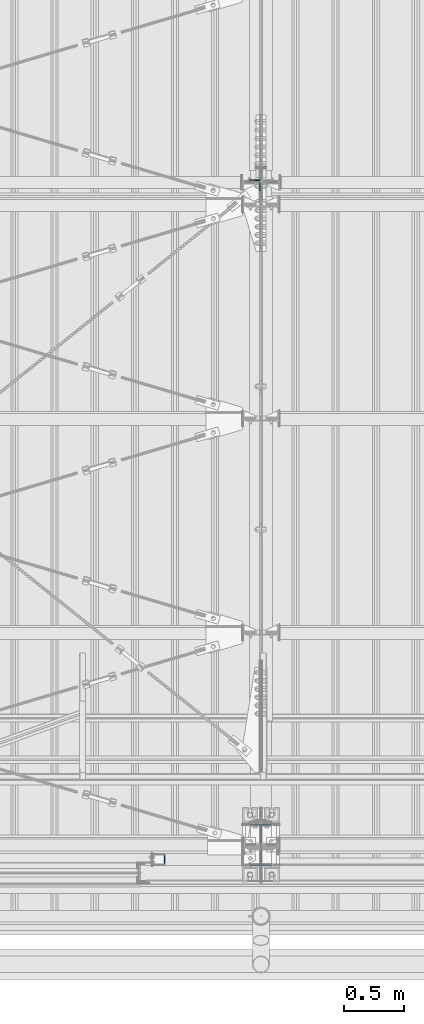
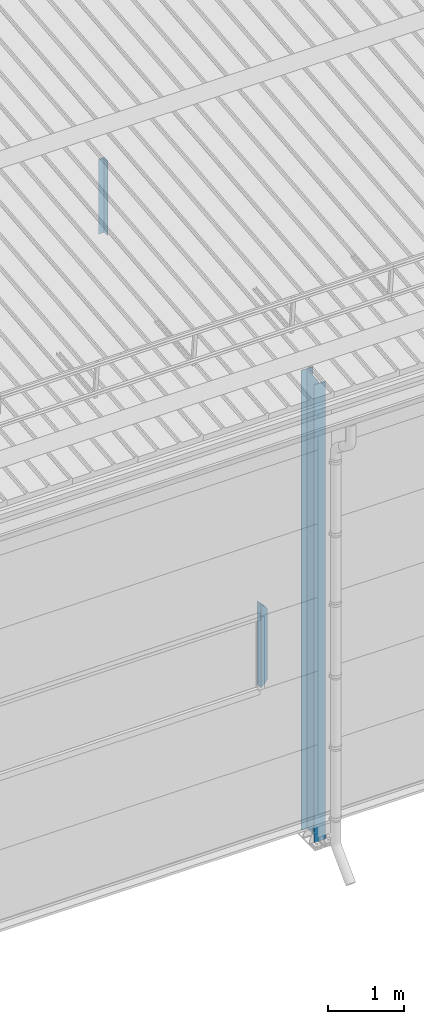
# One storey, part 226 of 709: 3 columns, 3 elements without a shape of their own.
"""IFC4 building model written with IfcOpenShell, lengths in millimetres."""

import ifcopenshell
import ifcopenshell.guid

model = None  # the IFC model being written
_history = None  # IfcOwnerHistory: only IFC2X3 demands one
_inside = {}  # id of a spatial element -> (the spatial element, [elements in it])
_under = {}  # id of a project, library or spatial element -> (it, [spatial elements below it])
_declared = {}  # id of a project -> (the project, [libraries it declares])
_typed = {}  # id of a type object -> (the type object, [elements of that type])
_made_of = {}  # id of a material, layer set ... -> (it, [elements and type objects made of it])


def new_model(schema):
    """Start an empty IFC model of exactly this schema.

    Asked for "IFC4X3", IfcOpenShell would pick the latest addendum, in which some entities
    have other attributes; the version numbers below select the first issue.
    IFC2X3 requires an IfcOwnerHistory on every rooted entity: one is made here for all.
    """
    global model, _history
    if schema == "IFC4X3":
        model = ifcopenshell.file(schema_version=(4, 3, 0, 0))
    else:
        model = ifcopenshell.file(schema=schema)
    _inside.clear()
    _under.clear()
    _declared.clear()
    _typed.clear()
    _made_of.clear()
    _history = None
    if model.schema == "IFC2X3":
        org = make("IfcOrganization", Name="unknown")
        user = make(
            "IfcPersonAndOrganization",
            ThePerson=make("IfcPerson", FamilyName="unknown"),
            TheOrganization=org,
        )
        app = make(
            "IfcApplication",
            ApplicationDeveloper=org,
            Version="unknown",
            ApplicationFullName="unknown",
            ApplicationIdentifier="unknown",
        )
        _history = make(
            "IfcOwnerHistory",
            OwningUser=user,
            OwningApplication=app,
            ChangeAction="ADDED",
            CreationDate=0,
        )
    return model


def make(cls, **values):
    """One entity of the class cls with the attributes given. An attribute that is None is left unset."""
    return model.create_entity(
        cls, **{name: value for name, value in values.items() if value is not None}
    )


def rooted(cls, **values):
    """An entity with a GlobalId (a new one), such as an element, a storey or a relation."""
    return make(cls, GlobalId=ifcopenshell.guid.new(), OwnerHistory=_history, **values)


def si_unit(unit_type, name, prefix=None):
    """IfcSIUnit, for example si_unit("LENGTHUNIT", "METRE", prefix="MILLI")."""
    return make("IfcSIUnit", UnitType=unit_type, Prefix=prefix, Name=name)


def assignment(units):
    """IfcUnitAssignment: the units of a project."""
    return None if units is None else make("IfcUnitAssignment", Units=units)


def point(xyz):
    """IfcCartesianPoint."""
    return None if xyz is None else make("IfcCartesianPoint", Coordinates=xyz)


def direction(xyz):
    """IfcDirection."""
    return None if xyz is None else make("IfcDirection", DirectionRatios=xyz)


def frame(location, z_axis=None, x_axis=None):
    """IfcAxis2Placement3D, a coordinate frame: its origin and axes. An axis left out is left unset."""
    return make(
        "IfcAxis2Placement3D",
        Location=point(location),
        Axis=direction(z_axis),
        RefDirection=direction(x_axis),
    )


def origin_with_axes():
    """The frame at (0, 0, 0) with the z axis (0, 0, 1) and the x axis (1, 0, 0) written out."""
    return frame((0.0, 0.0, 0.0), z_axis=(0.0, 0.0, 1.0), x_axis=(1.0, 0.0, 0.0))


def place(relative_to, where):
    """IfcLocalPlacement: puts the frame where relative to a parent placement (None: the world)."""
    return make(
        "IfcLocalPlacement", PlacementRelTo=relative_to, RelativePlacement=where
    )


def context(
    kind, dimensions, precision=None, world=None, true_north=None, identifier=None
):
    """IfcGeometricRepresentationContext, for example the 3D "Model" context."""
    return make(
        "IfcGeometricRepresentationContext",
        ContextIdentifier=identifier,
        ContextType=kind,
        CoordinateSpaceDimension=dimensions,
        Precision=precision,
        WorldCoordinateSystem=world,
        TrueNorth=true_north,
    )


def subcontext(parent, identifier, kind, view, scale=None):
    """IfcGeometricRepresentationSubContext, for example "Body" below "Model"."""
    return make(
        "IfcGeometricRepresentationSubContext",
        ContextIdentifier=identifier,
        ContextType=kind,
        ParentContext=parent,
        TargetScale=scale,
        TargetView=view,
    )


def project(units=None, contexts=None):
    """IfcProject with its units and contexts."""
    return rooted(
        "IfcProject",
        Name="project",
        RepresentationContexts=contexts,
        UnitsInContext=assignment(units),
    )


def spatial(cls, under=None, at=None, **own):
    """A site, building, storey or space (cls), placed at a placement, below another one or the project."""
    s = rooted(cls, ObjectPlacement=at, **own)
    if under is not None:
        _under.setdefault(under.id(), (under, []))[1].append(s)
    return s


def point_list(points):
    """IfcCartesianPointList2D or 3D."""
    cls = (
        "IfcCartesianPointList2D" if len(points[0]) == 2 else "IfcCartesianPointList3D"
    )
    return make(cls, CoordList=points)


def polygons(points, faces, closed=None, point_numbers=None):
    """IfcPolygonalFaceSet: a face is its outer loop, then its inner loops; points numbered from 1."""
    made = []
    for loops in faces:
        if len(loops) == 1:
            made.append(make("IfcIndexedPolygonalFace", CoordIndex=loops[0]))
        else:
            made.append(
                make(
                    "IfcIndexedPolygonalFaceWithVoids",
                    CoordIndex=loops[0],
                    InnerCoordIndices=loops[1:],
                )
            )
    return make(
        "IfcPolygonalFaceSet",
        Coordinates=point_list(points),
        Closed=closed,
        Faces=made,
        PnIndex=point_numbers,
    )


def shape(context_of_items, identifier, shape_type, items):
    """IfcShapeRepresentation: the items that make up one representation, for example the "Body"."""
    return make(
        "IfcShapeRepresentation",
        ContextOfItems=context_of_items,
        RepresentationIdentifier=identifier,
        RepresentationType=shape_type,
        Items=items,
    )


def material(Name=None, Category=None):
    """IfcMaterial."""
    return make("IfcMaterial", Name=Name, Category=Category)


def made_of(thing, what):
    """Note that an element or type object is made of a material, layer set ...; save() writes the relation."""
    if what is not None:
        _made_of.setdefault(what.id(), (what, []))[1].append(thing)
    return thing


def element(
    cls,
    number,
    at=None,
    inside=None,
    cuts=None,
    type_object=None,
    material=None,
    context=None,
    identifier="Body",
    shape_type=None,
    held_by="IfcProductDefinitionShape",
    body=None,
    shapes=None,
    **own,
):
    """One element of the class cls, such as IfcWall. Its Tag is "e" and its number.

    at: its placement. inside: the storey or other place that contains it. cuts: it is an
    opening in that element (IfcRelVoidsElement). A single representation is given by context,
    identifier, shape_type and body (its items); several are given by shapes. held_by: the class
    of the entity that holds the representations. save() writes the other relations.
    """
    e = rooted(cls, Tag="e%d" % number, ObjectPlacement=at, **own)
    if body is not None:
        shapes = [shape(context, identifier, shape_type, body)]
    if shapes is not None:
        e.Representation = make(held_by, Representations=shapes)
    if inside is not None:
        _inside.setdefault(inside.id(), (inside, []))[1].append(e)
    if cuts is not None:
        rooted(
            "IfcRelVoidsElement", RelatingBuildingElement=cuts, RelatedOpeningElement=e
        )
    if type_object is not None:
        _typed.setdefault(type_object.id(), (type_object, []))[1].append(e)
    return made_of(e, material)


def aggregate(whole, parts):
    """IfcRelAggregates: a whole, such as a stair, and the parts it consists of."""
    return rooted("IfcRelAggregates", RelatingObject=whole, RelatedObjects=parts)


def save(model, path):
    """Write the relations noted so far, then the file.

    IfcRelAggregates (storeys below a building ...), IfcRelContainedInSpatialStructure (elements
    in a storey), IfcRelDefinesByType, IfcRelAssociatesMaterial and IfcRelDeclares: one each for
    every whole, place, type object, material and project.
    """
    for whole, parts in _under.values():
        aggregate(whole, parts)
    for where, things in _inside.values():
        rooted(
            "IfcRelContainedInSpatialStructure",
            RelatedElements=things,
            RelatingStructure=where,
        )
    for kind, things in _typed.values():
        rooted("IfcRelDefinesByType", RelatedObjects=things, RelatingType=kind)
    for what, things in _made_of.values():
        rooted("IfcRelAssociatesMaterial", RelatedObjects=things, RelatingMaterial=what)
    for by, libraries in _declared.values():
        rooted("IfcRelDeclares", RelatingContext=by, RelatedDefinitions=libraries)
    model.write(path)


model = new_model("IFC4")

# Units and contexts
model_context = context("Model", 3, precision=0.2, world=origin_with_axes(), true_north=direction((0.0, 1.0)))
body_context = subcontext(model_context, "Body", "Model", "MODEL_VIEW")
ifc_project = project(units=[si_unit("LENGTHUNIT", "METRE", prefix="MILLI"), si_unit("AREAUNIT", "SQUARE_METRE"), si_unit("VOLUMEUNIT", "CUBIC_METRE"), si_unit("MASSUNIT", "GRAM", prefix="KILO"), si_unit("TIMEUNIT", "SECOND"), si_unit("PLANEANGLEUNIT", "RADIAN"), si_unit("SOLIDANGLEUNIT", "STERADIAN"), si_unit("THERMODYNAMICTEMPERATUREUNIT", "DEGREE_CELSIUS"), si_unit("LUMINOUSINTENSITYUNIT", "LUMEN")], contexts=[model_context])

# Site, building, storey
site_placement = place(None, origin_with_axes())
site = spatial("IfcSite", under=ifc_project, at=site_placement, CompositionType="ELEMENT")
building_placement = place(site_placement, origin_with_axes())
building = spatial("IfcBuilding", under=site, at=building_placement, Name="Undefined", CompositionType="ELEMENT")
storey_placement = place(building_placement, origin_with_axes())
storey = spatial("IfcBuildingStorey", under=building, at=storey_placement, Name="Undefined", CompositionType="ELEMENT", Elevation=0.0)

# Assembly, column
assembly_1_placement = place(storey_placement, frame((10000.0, 173.0, -200.0), z_axis=(-1.0, 0.0, 0.0), x_axis=(0.0, 0.0, 1.0)))
assembly_1 = element("IfcElementAssembly", 1, at=assembly_1_placement, inside=storey)
ifc_material_1 = material(Name="C355-5", Category="STEEL")
column_1_placement = place(assembly_1_placement, origin_with_axes())
column_1 = element("IfcColumn", 2, at=column_1_placement, material=ifc_material_1, ObjectType="413", context=body_context, shape_type="Tessellation", body=[
    polygons([(25.0, -173.0, -87.0), (25.0, -164.0, -87.0), (7421.82297, -164.0, -87.0), (7420.92297, -173.0, -87.0), (25.0, -164.0, -3.0), (7421.82297, -164.0, -3.0), (25.0, 164.0, -3.0), (7454.62297, 164.0, -3.0), (25.0, 164.0, -87.0), (7454.62297, 164.0, -87.0), (25.0, 173.0, -87.0), (7455.52297, 173.0, -87.0), (25.0, 173.0, 87.0), (7455.52297, 173.0, 87.0), (25.0, 164.0, 87.0), (7454.62297, 164.0, 87.0), (25.0, 164.0, 3.0), (7454.62297, 164.0, 3.0), (25.0, -164.0, 3.0), (7421.82297, -164.0, 3.0), (25.0, -164.0, 87.0), (7421.82297, -164.0, 87.0), (25.0, -173.0, 87.0), (7420.92297, -173.0, 87.0)], [[[1, 2, 3, 4]], [[2, 5, 6, 3]], [[5, 7, 8, 6]], [[7, 9, 10, 8]], [[9, 11, 12, 10]], [[11, 13, 14, 12]], [[13, 15, 16, 14]], [[15, 17, 18, 16]], [[17, 19, 20, 18]], [[19, 21, 22, 20]], [[21, 23, 24, 22]], [[23, 1, 4, 24]], [[6, 8, 10, 12, 14, 16, 18, 20, 22, 24, 4, 3]], [[23, 21, 19, 17, 15, 13, 11, 9, 7, 5, 2, 1]]], closed=True),
])
aggregate(assembly_1, [column_1])

assembly_2_placement = place(storey_placement, frame((9949.0, 5648.7, 6024.30002), z_axis=(0.0, -1.0, 0.0), x_axis=(0.0, 0.0, 1.0)))
assembly_2 = element("IfcElementAssembly", 3, at=assembly_2_placement, inside=storey)
ifc_material_2 = material(Name="C345-5", Category="STEEL")
column_2_placement = place(assembly_2_placement, origin_with_axes())
column_2 = element("IfcColumn", 4, at=column_2_placement, material=ifc_material_2, ObjectType="436", context=body_context, shape_type="Tessellation", body=[
    polygons([(185.7, -45.0, -45.0), (185.7, 45.0, -45.0), (1399.0509, 45.0, -45.0), (1399.0509, -45.0, -45.0), (185.7, 45.0, -39.0), (1399.0509, 45.0, -39.0), (185.7, -39.0, -39.0), (1399.0509, -39.0, -39.0), (185.7, -39.0, 45.0), (1399.0509, -39.0, 45.0), (185.7, -45.0, 45.0), (1399.0509, -45.0, 45.0)], [[[1, 2, 3, 4]], [[2, 5, 6, 3]], [[5, 7, 8, 6]], [[7, 9, 10, 8]], [[9, 11, 12, 10]], [[11, 1, 4, 12]], [[6, 8, 10, 12, 4, 3]], [[11, 9, 7, 5, 2, 1]]], closed=True),
])
aggregate(assembly_2, [column_2])

assembly_3_placement = place(storey_placement, frame((9150.0, 50.0, 2600.0), z_axis=(1.0, 0.0, 0.0), x_axis=(0.0, 0.0, 1.0)))
assembly_3 = element("IfcElementAssembly", 5, at=assembly_3_placement, inside=storey)
ifc_material_3 = material(Name="C355", Category="STEEL")
column_3_placement = place(assembly_3_placement, origin_with_axes())
column_3 = element("IfcColumn", 6, at=column_3_placement, material=ifc_material_3, ObjectType="493", context=body_context, shape_type="Tessellation", body=[
    polygons([(10.0, -50.0, -50.0), (10.0, 50.0, -50.0), (1360.0, 50.0, -50.0), (1360.0, -50.0, -50.0), (110.0, -50.0, 50.0), (1260.0, -50.0, 50.0), (110.0, 50.0, 50.0), (1260.0, 50.0, 50.0), (107.0, 47.0, 47.0), (13.0, 47.0, -47.0), (1357.0, 47.0, -47.0), (1263.0, 47.0, 47.0), (107.0, -47.0, 47.0), (1263.0, -47.0, 47.0), (13.0, -47.0, -47.0), (1357.0, -47.0, -47.0)], [[[1, 2, 3, 4]], [[5, 1, 4, 6]], [[7, 5, 6, 8]], [[2, 7, 8, 3]], [[1, 5, 7, 2], [15, 10, 9, 13]], [[9, 10, 11, 12]], [[13, 9, 12, 14]], [[15, 13, 14, 16]], [[10, 15, 16, 11]], [[6, 4, 3, 8], [14, 12, 11, 16]]], closed=True),
])
aggregate(assembly_3, [column_3])

save(model, "model.ifc")
